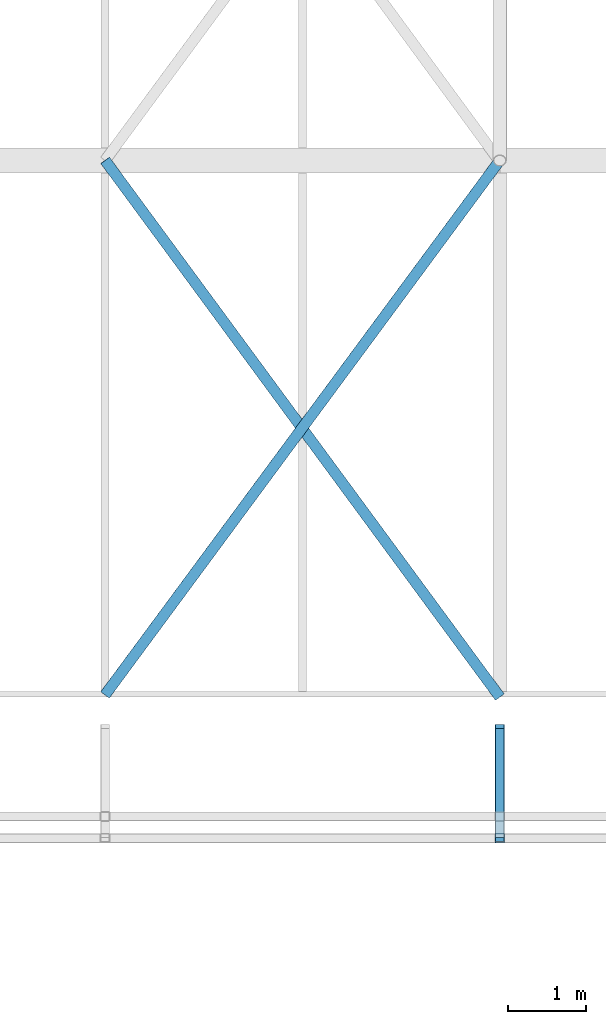
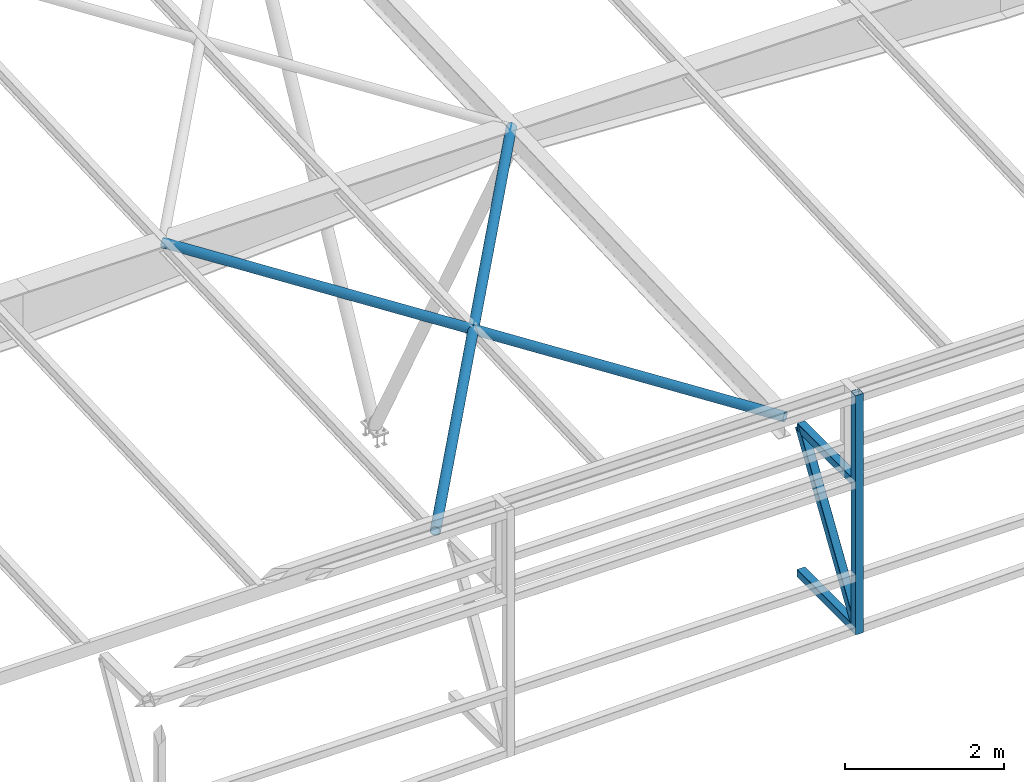
# One storey, part 111 of 215: 5 beams, 1 member, 6 elements without a shape of their own.
"""IFC2X3 building model written with IfcOpenShell, lengths in millimetres."""

from ifc_helpers import new_model, si_unit, frame, origin_with_axes, origin_2d_with_axis, place, context, subcontext, project, spatial, hollow_rectangle, hollow_circle, extrude, material, type_object, element, aggregate, save


model = new_model("IFC2X3")

# Units and contexts
model_context = context("Model", 3, precision=1e-05, world=origin_with_axes())
body_context = subcontext(model_context, "Body", "Model", "MODEL_VIEW")
ifc_project = project(units=[si_unit("LENGTHUNIT", "METRE", prefix="MILLI"), si_unit("AREAUNIT", "SQUARE_METRE"), si_unit("VOLUMEUNIT", "CUBIC_METRE"), si_unit("MASSUNIT", "GRAM", prefix="KILO"), si_unit("TIMEUNIT", "SECOND"), si_unit("PLANEANGLEUNIT", "RADIAN"), si_unit("SOLIDANGLEUNIT", "STERADIAN"), si_unit("THERMODYNAMICTEMPERATUREUNIT", "DEGREE_CELSIUS"), si_unit("LUMINOUSINTENSITYUNIT", "LUMEN")], contexts=[model_context])

# Site, building, storey
site_placement = place(None, origin_with_axes())
site = spatial("IfcSite", under=ifc_project, at=site_placement, CompositionType="ELEMENT")
building_placement = place(site_placement, origin_with_axes())
building = spatial("IfcBuilding", under=site, at=building_placement, Name="Undefined", CompositionType="ELEMENT")
storey_placement = place(building_placement, origin_with_axes())
storey = spatial("IfcBuildingStorey", under=building, at=storey_placement, Name="Undefined", CompositionType="ELEMENT", Elevation=0.0)

# Assembly, beam
assembly_1_placement = place(storey_placement, origin_with_axes())
assembly_1 = element("IfcElementAssembly", 1, at=assembly_1_placement, inside=storey, Name="Steel Assembly", AssemblyPlace="NOTDEFINED", PredefinedType="RIGID_FRAME")
ifc_material_1 = material(Name="STEEL/S275JR")
beam_type_1 = type_object("IfcBeamType", PredefinedType="NOTDEFINED")
beam_1_placement = place(assembly_1_placement, frame((129525.007188389, 34554.9177696335, 713.363965240432), z_axis=(0.0, 0.0, 1.0), x_axis=(-6.93889390390723e-18, -1.0, -3.46944695195361e-18)))
beam_1 = element("IfcBeam", 2, at=beam_1_placement, type_object=beam_type_1, material=ifc_material_1, Name="LISSE", context=body_context, shape_type="SweptSolid", body=[
    extrude(hollow_rectangle(XDim=120.0, YDim=120.0, WallThickness=4.0, InnerFilletRadius=4.0, OuterFilletRadius=8.0, at=origin_2d_with_axis()), frame((1404.9181154153, 1.48751491493898e-19, -2.84217094304217e-14), z_axis=(-1.0, 0.0, 0.0), x_axis=(-6.93889390390723e-18, -1.0, -3.46944695195361e-18)), (0.0, 0.0, 1.0), 1404.9),
])
aggregate(assembly_1, [beam_1])

assembly_2_placement = place(storey_placement, origin_with_axes())
assembly_2 = element("IfcElementAssembly", 3, at=assembly_2_placement, inside=storey, Name="Steel Assembly", AssemblyPlace="NOTDEFINED", PredefinedType="RIGID_FRAME")
beam_2_placement = place(assembly_2_placement, frame((129525.008596304, 34554.9143638247, 2963.99602185051), z_axis=(0.0, 0.0, -1.0), x_axis=(-4.41999996209638e-07, -0.999999999999642, 7.22000000069896e-07)))
beam_2 = element("IfcBeam", 4, at=beam_2_placement, type_object=beam_type_1, material=ifc_material_1, Name="LISSE", context=body_context, shape_type="SweptSolid", body=[
    extrude(hollow_rectangle(XDim=120.0, YDim=120.0, WallThickness=4.0, InnerFilletRadius=4.0, OuterFilletRadius=8.0, at=origin_2d_with_axis()), frame((1404.89231313232, 5.39143026605448e-20, -1.48748759570922e-19), z_axis=(-1.0, 0.0, 0.0), x_axis=(-6.93889390390723e-18, -1.0, -3.46944695195361e-18)), (0.0, 0.0, 1.0), 1404.9),
])
aggregate(assembly_2, [beam_2])

assembly_3_placement = place(storey_placement, origin_with_axes())
assembly_3 = element("IfcElementAssembly", 5, at=assembly_3_placement, inside=storey, Name="Steel Assembly", AssemblyPlace="NOTDEFINED", PredefinedType="RIGID_FRAME")
beam_3_placement = place(assembly_3_placement, frame((129525.008091857, 33139.951471091, 4339.19100776318), z_axis=(1.91399999311775e-06, -0.999999999998168, 0.0), x_axis=(0.0, 0.0, -1.0)))
beam_3 = element("IfcBeam", 6, at=beam_3_placement, type_object=beam_type_1, material=ifc_material_1, Name="LISSE", context=body_context, shape_type="SweptSolid", body=[
    extrude(hollow_rectangle(XDim=120.0, YDim=120.0, WallThickness=4.0, InnerFilletRadius=4.0, OuterFilletRadius=8.0, at=origin_2d_with_axis()), frame((3684.48338432547, 0.0, 0.0), z_axis=(-1.0, 0.0, 0.0), x_axis=(-6.93889390390723e-18, -1.0, -3.46944695195361e-18)), (0.0, 0.0, 1.0), 3684.5),
])
aggregate(assembly_3, [beam_3])

assembly_4_placement = place(storey_placement, origin_with_axes())
assembly_4 = element("IfcElementAssembly", 7, at=assembly_4_placement, inside=storey, Name="Steel Assembly", AssemblyPlace="NOTDEFINED", PredefinedType="RIGID_FRAME")
ifc_material_2 = material(Name="STEEL/S235JR")
beam_type_2 = type_object("IfcBeamType", PredefinedType="NOTDEFINED")
beam_4_placement = place(assembly_4_placement, frame((129525.008357403, 34957.7222962608, 2859.39689725141), z_axis=(-2.1980000026525e-06, -0.0399625230126959, 0.999201179317573), x_axis=(-0.592206527090233, 0.805142594122678, 0.0321998820049062)))
beam_4 = element("IfcBeam", 8, at=beam_4_placement, type_object=beam_type_2, material=ifc_material_2, context=body_context, shape_type="SweptSolid", body=[
    extrude(hollow_circle(Radius=69.84999845, WallThickness=8.0, at=origin_2d_with_axis()), frame((8578.08767439074, 4.6129891210034e-13, 0.0), z_axis=(-1.0, 0.0, 0.0), x_axis=(-6.93889390390723e-18, -1.0, -3.46944695195361e-18)), (0.0, 0.0, 1.0), 8578.1),
])
aggregate(assembly_4, [beam_4])

assembly_5_placement = place(storey_placement, origin_with_axes())
assembly_5 = element("IfcElementAssembly", 9, at=assembly_5_placement, inside=storey, Name="Steel Assembly", AssemblyPlace="NOTDEFINED", PredefinedType="RIGID_FRAME")
beam_5_placement = place(assembly_5_placement, frame((124445.008848245, 34985.3164388583, 2860.48941961704), z_axis=(-2.1980000026525e-06, -0.0399625230126959, 0.999201179317573), x_axis=(0.593745678310852, 0.804009941420935, 0.0321571700168357)))
beam_5 = element("IfcBeam", 10, at=beam_5_placement, type_object=beam_type_2, material=ifc_material_2, context=body_context, shape_type="SweptSolid", body=[
    extrude(hollow_circle(Radius=69.84999845, WallThickness=8.0, at=origin_2d_with_axis()), frame((8555.8508978914, 9.99982135717047e-13, 4.54747350886464e-13), z_axis=(-1.0, 0.0, 0.0), x_axis=(-6.93889390390723e-18, -1.0, -3.46944695195361e-18)), (0.0, 0.0, 1.0), 8555.9),
])
aggregate(assembly_5, [beam_5])

# Assembly, member
assembly_6_placement = place(storey_placement, origin_with_axes())
assembly_6 = element("IfcElementAssembly", 11, at=assembly_6_placement, inside=storey, Name="Steel Assembly", AssemblyPlace="NOTDEFINED", PredefinedType="RIGID_FRAME")
member_type = type_object("IfcMemberType", PredefinedType="NOTDEFINED")
member_placement = place(assembly_6_placement, frame((129525.011772691, 33149.9998158678, 773.363957740431), z_axis=(-0.00148057000013443, -0.841762412076592, 0.53984613504912), x_axis=(-1.22099999913544e-06, 0.539846727945855, 0.841763333915575)))
member = element("IfcMember", 12, at=member_placement, type_object=member_type, material=ifc_material_1, Name="LISSE", context=body_context, shape_type="SweptSolid", body=[
    extrude(hollow_rectangle(XDim=120.0, YDim=120.0, WallThickness=4.0, InnerFilletRadius=4.0, OuterFilletRadius=8.0, at=origin_2d_with_axis()), frame((2602.43227108986, -5.64312544412403e-16, 3.92690682983086e-12), z_axis=(-1.0, 0.0, 0.0), x_axis=(-6.93889390390723e-18, -1.0, -3.46944695195361e-18)), (0.0, 0.0, 1.0), 2602.4),
])
aggregate(assembly_6, [member])

save(model, "model.ifc")
